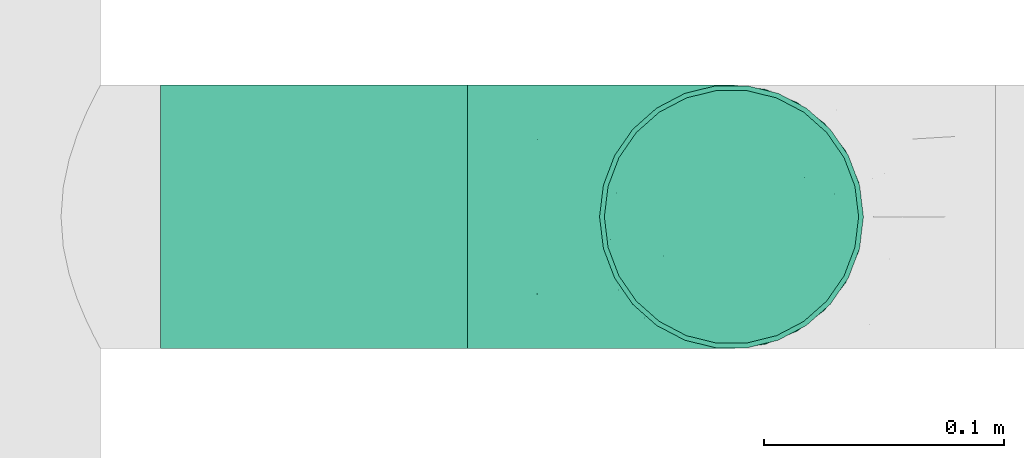
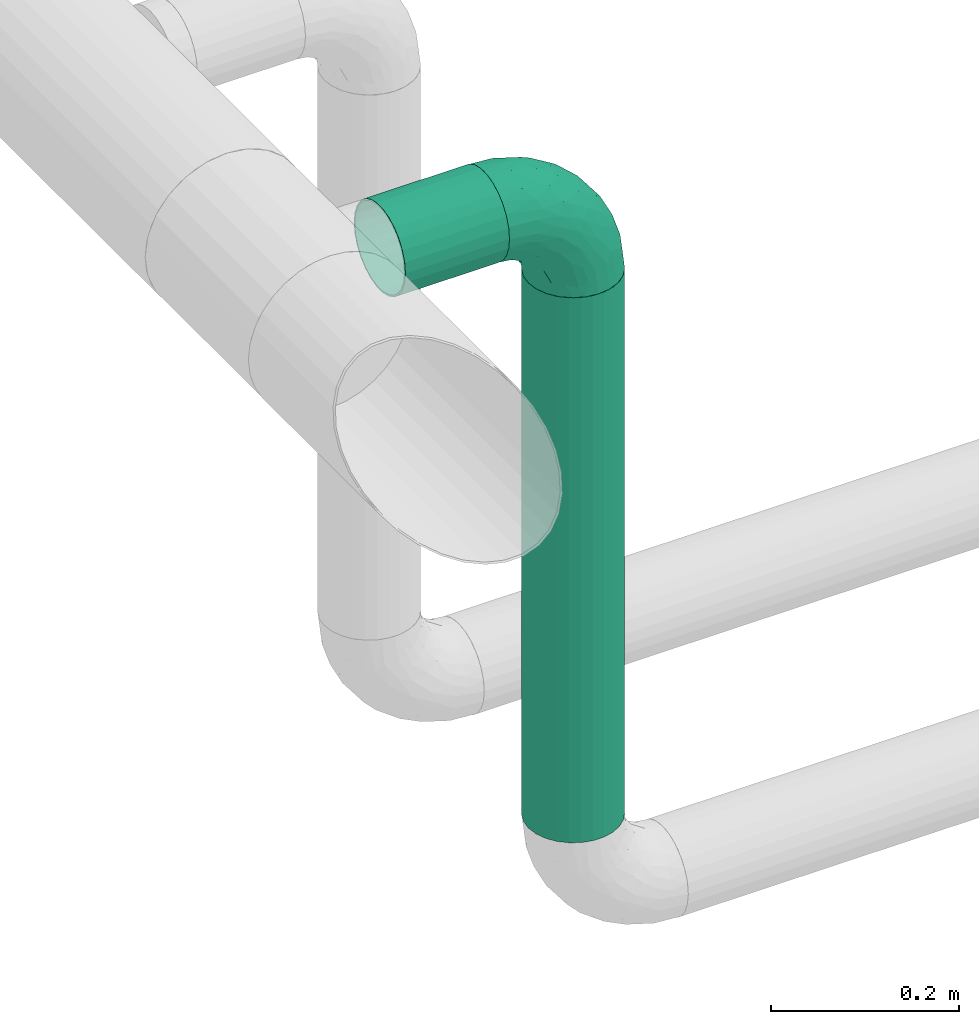
# One storey, part 67 of 91: 2 flow segments, 1 flow fitting.
"""IFC2X3 building model written with IfcOpenShell, lengths in millimetres."""

from ifc_helpers import new_model, entity, si_unit, converted_unit, derived_unit, direction, frame, origin_with_axes, origin_2d_with_axis, place, context, subcontext, project, spatial, hollow_circle, extrude, open_shell, surface_model, source, transform, mapped, material, layer, layer_set, layer_usage, type_object, element, save


model = new_model("IFC2X3")

# Units and contexts
model_context = context("Model", 3, precision=1e-05, world=origin_with_axes(), true_north=direction((0.0, 1.0)))
body_context = subcontext(model_context, "Body", "Model", "MODEL_VIEW")
ifc_project = project(units=[si_unit("AREAUNIT", "SQUARE_METRE"), si_unit("VOLUMEUNIT", "CUBIC_METRE", prefix="DECI"), si_unit("TIMEUNIT", "SECOND"), si_unit("THERMODYNAMICTEMPERATUREUNIT", "DEGREE_CELSIUS"), si_unit("PRESSUREUNIT", "PASCAL"), si_unit("MASSUNIT", "GRAM", prefix="KILO"), si_unit("LENGTHUNIT", "METRE", prefix="MILLI"), si_unit("POWERUNIT", "WATT"), si_unit("ELECTRICCURRENTUNIT", "AMPERE"), si_unit("ELECTRICVOLTAGEUNIT", "VOLT"), derived_unit("VOLUMETRICFLOWRATEUNIT", [(si_unit("VOLUMEUNIT", "CUBIC_METRE", prefix="DECI"), 1), (si_unit("TIMEUNIT", "SECOND"), -1)]), derived_unit("LINEARVELOCITYUNIT", [(si_unit("LENGTHUNIT", "METRE"), 1), (si_unit("TIMEUNIT", "SECOND"), -1)]), derived_unit("MASSDENSITYUNIT", [(si_unit("MASSUNIT", "GRAM", prefix="KILO"), 1), (si_unit("VOLUMEUNIT", "CUBIC_METRE"), -1)]), converted_unit("PLANEANGLEUNIT", "DEGREE", entity("IfcRatioMeasure", 0.01745), si_unit("PLANEANGLEUNIT", "RADIAN"), dimensions=[0, 0, 0, 0, 0, 0, 0])], contexts=[model_context])

# Site, building, storey
site_placement = place(None, origin_with_axes())
site = spatial("IfcSite", under=ifc_project, at=site_placement, CompositionType="ELEMENT")
building_placement = place(site_placement, origin_with_axes())
building = spatial("IfcBuilding", under=site, at=building_placement, Name="mc-building", CompositionType="ELEMENT")
storey_placement = place(building_placement, frame((0.0, 0.0, 8700.0), z_axis=(0.0, 0.0, 1.0), x_axis=(1.0, 0.0, 0.0)))
storey = spatial("IfcBuildingStorey", under=building, at=storey_placement, CompositionType="ELEMENT", Elevation=8700.0)

# Flow segment
ifc_material = material(Name="FZ1")
ifc_layer = layer(ifc_material, 0.0)
ifc_layer_set = layer_set([ifc_layer], Name="FZ1")
ifc_layer_usage = layer_usage(ifc_layer_set, "AXIS1", "POSITIVE", 0.0)
duct_segment_type = type_object("IfcDuctSegmentType", PredefinedType="RIGIDSEGMENT")
shared_shape_1 = source(origin_with_axes(), body_context, "Body", "SweptSolid", [
    extrude(hollow_circle(Radius=55.0, WallThickness=2.0, at=origin_2d_with_axis()), frame((0.0, 0.0, 0.0), z_axis=(1.0, 0.0, 0.0), x_axis=(0.0, 1.0, 0.0)), (0.0, 0.0, 1.0), 709.0),
])
flow_segment_1_placement = place(storey_placement, frame((33727.76981, 7384.97206, 1234.0), z_axis=(0.0, 1.0, 0.0), x_axis=(0.0, 0.0, -1.0)))
element("IfcFlowSegment", 1, at=flow_segment_1_placement, inside=storey, type_object=duct_segment_type, material=ifc_layer_usage, context=body_context, shape_type="MappedRepresentation", body=[
    mapped(shared_shape_1, transform((0.0, 0.0, 0.0), scale=1.0)),
])

# Flow fitting
duct_fitting_type = type_object("IfcDuctFittingType", Name="BU", PredefinedType="BEND")
shared_shape_2 = source(origin_with_axes(), body_context, "Body", "SurfaceModel", [
    surface_model("IfcShellBasedSurfaceModel", [(-110.0, 0.0, -55.0), (-110.0, -14.23505, -53.12592), (-110.0, 14.23505, -53.12592), (-110.0, 53.12592, 14.23505), (-110.0, 27.5, -47.63139), (-110.0, 38.89087, -38.89087), (-110.0, -55.0, 0.0), (-110.0, -53.12592, 14.23505), (-110.0, -38.89087, -38.89087), (-110.0, -27.5, -47.63139), (-110.0, -53.12592, -14.23505), (-110.0, -47.63139, -27.5), (-110.0, -14.23505, 53.12592), (-110.0, 14.23505, 53.12592), (-110.0, 27.5, 47.63139), (-110.0, -47.63139, 27.5), (-110.0, -38.89087, 38.89087), (-110.0, -27.5, 47.63139), (-110.0, 0.0, 55.0), (-110.0, 55.0, 0.0), (-110.0, 53.12592, -14.23505), (-110.0, 47.63139, -27.5), (-110.0, 47.63139, 27.5), (-110.0, 38.89087, 38.89087), (-14.23505, 110.0, -53.12592), (-55.0, 110.0, 0.0), (0.0, 110.0, -55.0), (-27.5, 110.0, -47.63139), (-38.89087, 110.0, -38.89087), (-47.63139, 110.0, -27.5), (38.89087, 110.0, -38.89087), (53.12592, 110.0, 14.23505), (27.5, 110.0, -47.63139), (14.23505, 110.0, -53.12592), (47.63139, 110.0, -27.5), (53.12592, 110.0, -14.23505), (55.0, 110.0, 0.0), (-53.12592, 110.0, -14.23505), (-53.12592, 110.0, 14.23505), (-47.63139, 110.0, 27.5), (-38.89087, 110.0, 38.89087), (-27.5, 110.0, 47.63139), (0.0, 110.0, 55.0), (-14.23505, 110.0, 53.12592), (38.89087, 110.0, 38.89087), (47.63139, 110.0, 27.5), (27.5, 110.0, 47.63139), (14.23505, 110.0, 53.12592), (-64.21732, 48.68956, 43.63444), (-76.6405, 38.18013, 45.55988), (-60.44912, 32.56953, 51.94617), (-76.00813, 5.38378, 55.0), (-90.15553, 11.94394, 54.09138), (-78.5998, 26.77405, 50.81338), (-70.18771, 18.55163, 54.03432), (-75.55424, 54.2118, 32.41257), (-93.27622, 45.77614, 33.48188), (-96.12334, 22.13664, 50.81337), (-21.00813, 45.34362, 55.0), (-18.36258, 70.48427, 54.04484), (-32.04182, 59.64019, 52.24446), (-63.88653, 74.77858, 17.99134), (-74.66383, 63.08407, 19.92123), (-63.60674, 66.07878, 29.97482), (-99.597, 52.72185, 18.52927), (-93.11138, 56.59448, 10.50359), (-98.21577, 57.34403, 0.0), (-53.42855, 92.60092, 21.04759), (-88.54852, 54.8376, 21.04759), (-11.86161, 90.23965, 54.10313), (-5.38378, 76.00813, 55.0), (-57.34403, 98.21577, 0.0), (-56.64619, 93.12774, 10.22088), (-45.34362, 21.00813, 55.0), (-44.60838, 44.60838, 52.13415), (-92.68484, 35.46673, 43.63443), (-22.25266, 95.40765, 50.81337), (-35.97783, 90.61597, 43.63443), (-43.70931, 69.58671, 44.47149), (-27.23711, 77.39884, 50.81337), (-57.2828, 79.3123, 24.9774), (-58.67786, 84.31125, 16.04456), (-82.93277, 60.36161, 12.91784), (-49.88337, 54.51816, 47.224), (-74.57753, 66.83759, 9.55742), (-45.35812, 94.97281, 33.48188), (-59.18663, 88.95241, 0.0), (-51.517, 78.6292, 33.48188), (-65.14788, 80.03077, 0.0), (-56.45322, 62.06476, 39.63545), (-88.95241, 59.18663, 0.0), (-71.10913, 71.10913, 0.0), (-80.03077, 65.14788, 0.0), (-94.9309, 45.36788, -33.48188), (-93.11358, 56.60141, -10.46614), (-99.64997, 52.79499, -18.30015), (-90.20425, 36.08686, -43.63443), (-79.99933, 46.56772, -37.92748), (-76.00813, 5.38378, -55.0), (-72.75364, 19.68651, -53.60527), (-45.34362, 21.00813, -55.0), (-21.91957, 65.12078, -53.85897), (-5.38378, 76.00813, -55.0), (-21.00813, 45.34362, -55.0), (-35.41876, 92.89265, -43.63443), (-91.10309, 11.02766, -54.21832), (-45.77614, 93.27622, -33.48188), (-90.50474, 23.21022, -50.81337), (-70.92854, 33.31794, -49.51754), (-78.52933, 63.35627, -11.73997), (-24.91508, 84.05606, -50.81337), (-88.78941, 54.74452, -21.04759), (-69.59921, 57.34866, -33.48187), (-73.36422, 62.46673, -22.94182), (-63.49062, 67.59111, -28.46929), (-56.59448, 93.11138, -10.50359), (-54.8376, 88.54852, -21.04759), (-54.10679, 75.85581, -32.31867), (-57.75956, 31.09612, -52.80882), (-52.72185, 99.597, -18.52927), (-12.62913, 89.46304, -53.99097), (-34.46825, 66.46123, -50.04329), (-43.9837, 43.9837, -52.42279), (-65.78527, 72.58348, -17.68796), (-70.34468, 43.65295, -44.21951), (-57.47001, 51.99467, -44.91465), (-60.72547, 82.29174, -12.88567), (-42.34915, 74.24548, -43.63444), (-57.25194, 63.5016, -38.08211), (-80.95344, 53.56991, -29.32027), (-52.32891, 4.55257, -54.0482), (32.52942, 47.13398, -30.48571), (14.88266, 20.92917, -33.7947), (14.95561, 36.05775, -42.26543), (30.24048, 70.09027, -41.7461), (19.3559, 65.35825, -48.00507), (-70.35075, -46.44478, -19.5952), (-47.13398, -32.52942, -30.48571), (-28.49299, -30.5778, -16.4009), (-4.55257, 52.32891, -54.0482), (-22.4954, 22.4954, -53.25347), (-75.47368, -11.22546, -52.60718), (-81.32209, -51.5606, -9.98467), (-80.81763, -41.84862, -32.14655), (-70.09027, -30.24048, -41.7461), (-36.05774, -14.95561, -42.26543), (-9.15831, -10.852, -27.8997), (-65.35825, -19.3559, -48.00507), (11.22546, 75.47368, -52.60718), (3.94376, 43.9333, -50.53315), (-13.39742, 13.39743, -48.13058), (-43.9333, -3.94376, -50.53315), (49.37776, 67.29486, 0.0), (41.8609, 47.82256, -9.92641), (50.20582, 74.51695, -9.9731), (18.93131, 11.7156, -17.56239), (-27.5, -32.89419, 0.0), (-1.23348, -12.25375, -12.18106), (41.84862, 80.81763, -32.14655), (35.70604, 41.31408, -20.38235), (46.44478, 70.35075, -19.5952), (32.89419, 27.5, 0.0), (6.67262, -6.67262, 0.0), (-67.29486, -49.37776, 0.0), (-50.36265, -42.95545, -9.51562), (-5.47251, 5.47251, -39.92906), (-70.35075, -46.44478, 19.5952), (-74.51695, -50.20582, 9.9731), (-41.31407, -35.70604, 20.38235), (-47.13398, -32.52942, 30.48571), (-80.81763, -41.84862, 32.14655), (-4.55257, 52.32891, 54.0482), (11.22546, 75.47368, 52.60718), (-43.9333, -3.94376, 50.53315), (-65.35825, -19.3559, 48.00507), (-36.05774, -14.95561, 42.26543), (-70.09027, -30.24048, 41.7461), (-11.7156, -18.93131, 17.56239), (30.5778, 28.49299, 16.4009), (12.25375, 1.23348, 12.18106), (51.5606, 81.32209, 9.98467), (42.95545, 50.36265, 9.51562), (-75.47368, -11.22546, 52.60718), (-52.32891, 4.55257, 54.0482), (3.94376, 43.9333, 50.53315), (-22.4954, 22.4954, 53.25347), (-13.39742, 13.39743, 48.13058), (10.852, 9.15831, 27.8997), (-20.92916, -14.88266, 33.79469), (-47.82256, -41.8609, 9.92641), (32.52942, 47.13398, 30.48571), (46.44478, 70.35075, 19.5952), (41.84862, 80.81763, 32.14655), (30.24048, 70.09027, 41.7461), (19.3559, 65.35825, 48.00507), (14.95561, 36.05775, 42.26543), (-5.47251, 5.47251, 39.92906)], [open_shell([[[0, 1, 2]], [[2, 3, 4]], [[4, 3, 5]], [[2, 6, 7]], [[8, 6, 9]], [[1, 9, 6]], [[10, 6, 11]], [[8, 11, 6]], [[6, 2, 1]], [[12, 13, 14]], [[15, 2, 7]], [[16, 17, 2]], [[2, 17, 12]], [[12, 18, 13]], [[19, 20, 3]], [[5, 3, 21]], [[20, 21, 3]], [[22, 3, 2]], [[23, 22, 2]], [[12, 14, 2]], [[2, 14, 23]], [[15, 16, 2]], [[24, 25, 26]], [[27, 25, 24]], [[25, 28, 29]], [[28, 25, 27]], [[30, 26, 31]], [[26, 30, 32]], [[32, 33, 26]], [[34, 31, 35]], [[31, 34, 30]], [[35, 31, 36]], [[29, 37, 25]], [[38, 39, 26]], [[39, 40, 26]], [[41, 42, 40]], [[42, 26, 40]], [[42, 41, 43]], [[26, 44, 45]], [[31, 26, 45]], [[26, 46, 44]], [[47, 46, 26]], [[42, 47, 26]], [[25, 38, 26]], [[48, 49, 50]], [[18, 51, 52]], [[53, 54, 50]], [[55, 56, 49]], [[56, 22, 23]], [[13, 57, 14]], [[58, 59, 60]], [[61, 62, 63]], [[3, 64, 65]], [[53, 52, 54]], [[3, 65, 66]], [[67, 39, 38]], [[56, 68, 64]], [[65, 64, 68]], [[69, 59, 70]], [[38, 71, 72]], [[73, 58, 74]], [[75, 49, 56]], [[76, 69, 43]], [[53, 57, 52]], [[77, 78, 79]], [[41, 76, 43]], [[43, 69, 42]], [[55, 68, 56]], [[23, 14, 75]], [[76, 77, 79]], [[80, 67, 81]], [[62, 82, 68]], [[60, 78, 83]], [[62, 84, 82]], [[85, 77, 40]], [[81, 67, 72]], [[86, 72, 71]], [[87, 85, 67]], [[61, 81, 88]], [[77, 41, 40]], [[78, 77, 87]], [[23, 75, 56]], [[83, 89, 48]], [[85, 40, 39]], [[62, 68, 55]], [[89, 87, 63]], [[83, 48, 50]], [[57, 75, 14]], [[49, 75, 53]], [[67, 85, 39]], [[87, 77, 85]], [[63, 62, 55]], [[89, 55, 48]], [[80, 63, 87]], [[66, 65, 90]], [[66, 19, 3]], [[84, 91, 92]], [[92, 90, 82]], [[65, 82, 90]], [[61, 84, 62]], [[92, 82, 84]], [[68, 82, 65]], [[3, 22, 64]], [[56, 64, 22]], [[38, 25, 71]], [[81, 72, 86]], [[38, 72, 67]], [[91, 61, 88]], [[80, 81, 61]], [[63, 80, 61]], [[67, 80, 87]], [[77, 76, 41]], [[79, 59, 69]], [[79, 69, 76]], [[42, 69, 70]], [[60, 59, 79]], [[58, 70, 59]], [[78, 60, 79]], [[58, 60, 74]], [[52, 57, 13]], [[75, 57, 53]], [[18, 52, 13]], [[52, 51, 54]], [[51, 73, 54]], [[50, 73, 74]], [[73, 50, 54]], [[50, 74, 83]], [[60, 83, 74]], [[89, 83, 78]], [[87, 89, 78]], [[55, 89, 63]], [[50, 49, 53]], [[55, 49, 48]], [[81, 86, 88]], [[91, 84, 61]], [[5, 21, 93]], [[90, 94, 66]], [[20, 94, 95]], [[96, 93, 97]], [[98, 99, 100]], [[96, 4, 5]], [[101, 102, 103]], [[28, 27, 104]], [[2, 105, 0]], [[104, 106, 28]], [[99, 105, 107]], [[108, 107, 96]], [[90, 109, 94]], [[107, 2, 4]], [[20, 66, 94]], [[27, 24, 110]], [[109, 111, 94]], [[112, 113, 114]], [[37, 115, 71]], [[116, 106, 117]], [[99, 118, 100]], [[116, 115, 119]], [[37, 119, 115]], [[24, 120, 110]], [[121, 110, 101]], [[119, 106, 116]], [[101, 110, 120]], [[122, 103, 100]], [[117, 123, 116]], [[124, 125, 108]], [[115, 116, 126]], [[106, 29, 28]], [[26, 102, 120]], [[127, 104, 110]], [[97, 124, 96]], [[125, 122, 118]], [[128, 127, 125]], [[96, 5, 93]], [[115, 126, 86]], [[117, 106, 127]], [[111, 113, 129]], [[95, 93, 21]], [[97, 129, 112]], [[110, 104, 27]], [[106, 104, 127]], [[96, 107, 4]], [[99, 107, 108]], [[99, 108, 118]], [[105, 99, 98]], [[112, 114, 128]], [[121, 125, 127]], [[20, 19, 66]], [[109, 90, 92]], [[94, 111, 95]], [[91, 123, 109]], [[129, 113, 112]], [[93, 95, 111]], [[21, 20, 95]], [[71, 115, 86]], [[71, 25, 37]], [[123, 91, 88]], [[126, 116, 123]], [[123, 88, 126]], [[86, 126, 88]], [[37, 29, 119]], [[106, 119, 29]], [[129, 93, 111]], [[124, 112, 125]], [[0, 105, 98]], [[107, 105, 2]], [[125, 118, 108]], [[100, 118, 122]], [[93, 129, 97]], [[113, 111, 109]], [[109, 123, 113]], [[114, 123, 117]], [[123, 114, 113]], [[128, 114, 117]], [[127, 128, 117]], [[112, 128, 125]], [[103, 122, 101]], [[110, 121, 127]], [[101, 122, 121]], [[125, 121, 122]], [[26, 120, 24]], [[101, 120, 102]], [[96, 124, 108]], [[92, 91, 109]], [[112, 124, 97]], [[100, 130, 98]], [[131, 132, 133]], [[32, 134, 135]], [[136, 137, 138]], [[139, 140, 103]], [[98, 141, 0]], [[142, 10, 136]], [[143, 144, 137]], [[6, 10, 142]], [[137, 145, 146]], [[144, 147, 145]], [[143, 136, 11]], [[11, 136, 10]], [[8, 143, 11]], [[148, 149, 139]], [[8, 9, 144]], [[9, 1, 147]], [[130, 141, 98]], [[103, 140, 100]], [[148, 135, 149]], [[150, 151, 140]], [[152, 153, 154]], [[130, 140, 151]], [[148, 26, 33]], [[147, 1, 141]], [[155, 146, 132]], [[156, 138, 157]], [[134, 30, 158]], [[150, 140, 149]], [[158, 30, 34]], [[30, 134, 32]], [[153, 159, 160]], [[131, 160, 159]], [[144, 145, 137]], [[36, 152, 154]], [[146, 138, 137]], [[155, 161, 162]], [[158, 160, 131]], [[133, 149, 135]], [[156, 163, 164]], [[163, 142, 164]], [[139, 103, 102]], [[153, 152, 161]], [[34, 35, 160]], [[162, 157, 155]], [[132, 165, 133]], [[157, 146, 155]], [[140, 130, 100]], [[141, 130, 151]], [[141, 151, 147]], [[141, 1, 0]], [[102, 26, 148]], [[140, 139, 149]], [[102, 148, 139]], [[135, 33, 32]], [[151, 150, 145]], [[9, 147, 144]], [[151, 145, 147]], [[145, 165, 146]], [[135, 148, 33]], [[133, 135, 134]], [[131, 133, 134]], [[133, 165, 150]], [[133, 150, 149]], [[145, 150, 165]], [[132, 131, 159]], [[146, 165, 132]], [[160, 158, 34]], [[134, 158, 131]], [[144, 143, 8]], [[136, 143, 137]], [[155, 153, 161]], [[154, 153, 160]], [[153, 155, 159]], [[132, 159, 155]], [[160, 35, 154]], [[36, 154, 35]], [[164, 136, 138]], [[6, 142, 163]], [[136, 164, 142]], [[156, 164, 138]], [[156, 157, 162]], [[146, 157, 138]], [[15, 7, 166]], [[6, 163, 167]], [[168, 169, 166]], [[166, 169, 170]], [[171, 172, 70]], [[173, 174, 175]], [[17, 176, 174]], [[177, 156, 162]], [[176, 16, 170]], [[170, 16, 15]], [[161, 178, 179]], [[152, 180, 181]], [[182, 173, 183]], [[18, 12, 182]], [[184, 185, 186]], [[183, 185, 73]], [[183, 73, 51]], [[177, 187, 188]], [[189, 168, 166]], [[187, 178, 190]], [[16, 176, 17]], [[161, 152, 181]], [[45, 191, 31]], [[45, 44, 192]], [[192, 191, 45]], [[180, 36, 31]], [[193, 194, 195]], [[46, 47, 194]], [[193, 195, 190]], [[193, 44, 46]], [[172, 42, 70]], [[185, 58, 73]], [[189, 163, 156]], [[163, 189, 167]], [[70, 58, 171]], [[184, 171, 185]], [[169, 188, 175]], [[180, 31, 191]], [[192, 193, 190]], [[191, 190, 178]], [[182, 174, 173]], [[194, 47, 172]], [[190, 195, 187]], [[186, 185, 173]], [[162, 179, 177]], [[188, 196, 175]], [[179, 187, 177]], [[185, 171, 58]], [[172, 171, 184]], [[172, 184, 194]], [[172, 47, 42]], [[51, 18, 182]], [[185, 183, 173]], [[51, 182, 183]], [[174, 12, 17]], [[184, 186, 195]], [[46, 194, 193]], [[184, 195, 194]], [[195, 196, 187]], [[174, 182, 12]], [[175, 174, 176]], [[169, 175, 176]], [[175, 196, 186]], [[175, 186, 173]], [[195, 186, 196]], [[188, 169, 168]], [[187, 196, 188]], [[166, 170, 15]], [[176, 170, 169]], [[193, 192, 44]], [[191, 192, 190]], [[177, 189, 156]], [[167, 189, 166]], [[189, 177, 168]], [[188, 168, 177]], [[166, 7, 167]], [[6, 167, 7]], [[181, 191, 178]], [[36, 180, 152]], [[191, 181, 180]], [[161, 181, 178]], [[161, 179, 162]], [[187, 179, 178]]])]),
])
flow_fitting_placement = place(storey_placement, frame((33727.76981, 7384.97206, 1344.0), z_axis=(0.0, -1.0, 0.0), x_axis=(0.0, 0.0, 1.0)))
element("IfcFlowFitting", 2, at=flow_fitting_placement, inside=storey, type_object=duct_fitting_type, Name="BU", context=body_context, shape_type="MappedRepresentation", body=[
    mapped(shared_shape_2, transform((0.0, 0.0, 0.0), scale=1.0)),
])

# Flow segment
shared_shape_3 = source(origin_with_axes(), body_context, "Body", "SweptSolid", [
    extrude(hollow_circle(Radius=55.0, WallThickness=2.0, at=origin_2d_with_axis()), frame((0.0, 0.0, 0.0), z_axis=(1.0, 0.0, 0.0), x_axis=(0.0, 1.0, 0.0)), (0.0, 0.0, 1.0), 128.0),
])
flow_segment_2_placement = place(storey_placement, frame((33489.76981, 7384.97206, 1344.0), z_axis=(0.0, 0.0, 1.0), x_axis=(1.0, 0.0, 0.0)))
element("IfcFlowSegment", 3, at=flow_segment_2_placement, inside=storey, type_object=duct_segment_type, material=ifc_layer_usage, context=body_context, shape_type="MappedRepresentation", body=[
    mapped(shared_shape_3, transform((0.0, 0.0, 0.0), scale=1.0)),
])

save(model, "model.ifc")
